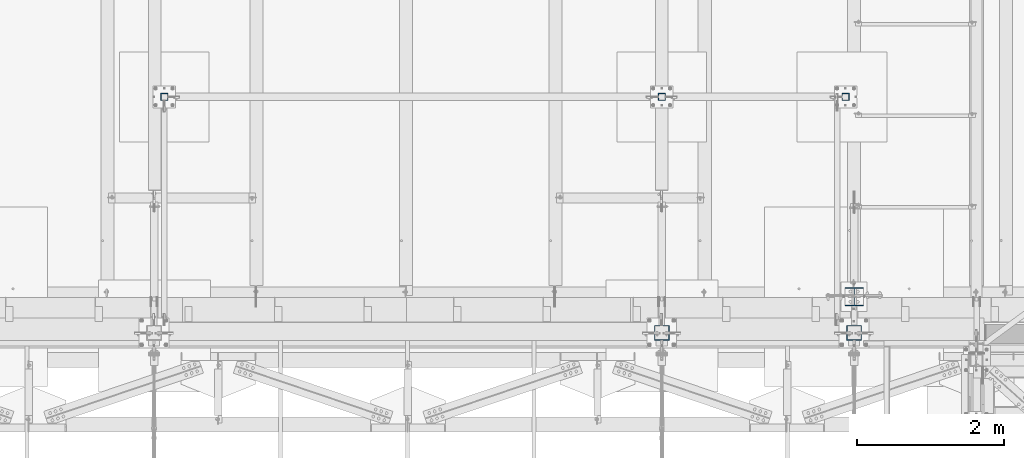
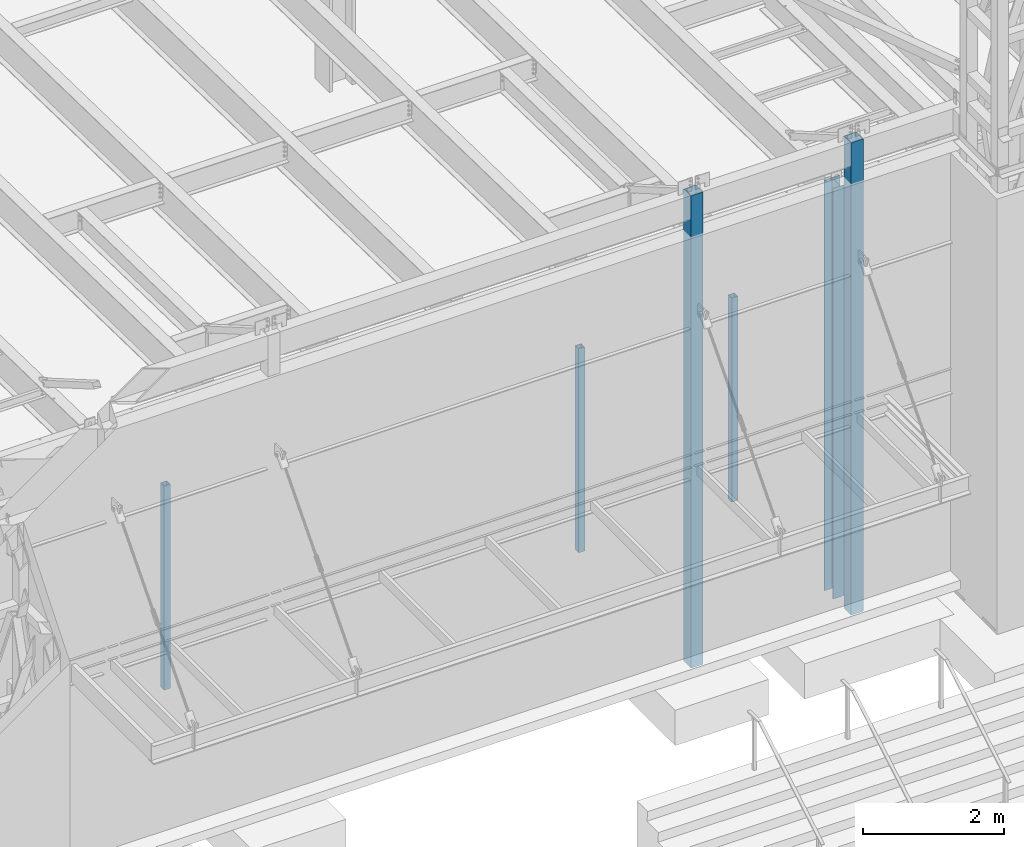
# One storey, part 893 of 1763: 6 columns, 6 elements without a shape of their own.
"""IFC2X3 building model written with IfcOpenShell, lengths in millimetres."""

from ifc_helpers import new_model, si_unit, frame, origin_with_axes, place, context, subcontext, project, spatial, faceted_brep, material, type_object, element, aggregate, save


model = new_model("IFC2X3")

# Units and contexts
model_context = context("Model", 3, precision=1e-05, world=origin_with_axes())
body_context = subcontext(model_context, "Body", "Model", "MODEL_VIEW")
ifc_project = project(units=[si_unit("LENGTHUNIT", "METRE", prefix="MILLI"), si_unit("AREAUNIT", "SQUARE_METRE"), si_unit("VOLUMEUNIT", "CUBIC_METRE"), si_unit("MASSUNIT", "GRAM", prefix="KILO"), si_unit("TIMEUNIT", "SECOND"), si_unit("PLANEANGLEUNIT", "RADIAN"), si_unit("SOLIDANGLEUNIT", "STERADIAN"), si_unit("THERMODYNAMICTEMPERATUREUNIT", "DEGREE_CELSIUS"), si_unit("LUMINOUSINTENSITYUNIT", "LUMEN")], contexts=[model_context])

# Site, building, storey
site_placement = place(None, origin_with_axes())
site = spatial("IfcSite", under=ifc_project, at=site_placement, CompositionType="ELEMENT")
building_placement = place(site_placement, origin_with_axes())
building = spatial("IfcBuilding", under=site, at=building_placement, Name="Undefined", CompositionType="ELEMENT")
storey_placement = place(building_placement, origin_with_axes())
storey = spatial("IfcBuildingStorey", under=building, at=storey_placement, Name="Undefined", CompositionType="ELEMENT", Elevation=0.0)

# Assembly, column
assembly_1_placement = place(storey_placement, origin_with_axes())
assembly_1 = element("IfcElementAssembly", 1, at=assembly_1_placement, inside=storey, Name="COLUMN", AssemblyPlace="NOTDEFINED", PredefinedType="RIGID_FRAME")
ifc_material_1 = material(Name="STEEL/A992")
column_type_1 = type_object("IfcColumnType", Name="W10X49", PredefinedType="NOTDEFINED")
column_1_placement = place(assembly_1_placement, frame((-49402.4372736983, -13716.0, 5029.2), z_axis=(0.0, 1.0, 0.0), x_axis=(0.0, 0.0, 1.0)))
column_1 = element("IfcColumn", 2, at=column_1_placement, type_object=column_type_1, material=ifc_material_1, Name="COLUMN", ObjectType="W10X49", context=body_context, shape_type="Brep", body=[
    faceted_brep([(69.8500000000085, 127.0, -127.0), (69.8500000000085, 127.0, -112.712500000001), (7156.45000000001, 127.0, -112.7125), (7156.45000000001, 127.0, -127.0), (69.8500000000085, 3.96875, -112.712500000001), (7156.45000000001, 3.96875, -112.7125), (69.8500000000085, 3.96875, 112.712500000001), (7156.45000000001, 3.96875, 112.7125), (69.8500000000085, 127.0, 112.712500000001), (7156.45000000001, 127.0, 112.7125), (69.8500000000085, 127.0, 127.0), (7156.45000000001, 127.0, 127.0), (69.8500000000085, -127.0, 127.0), (7156.45000000001, -127.0, 127.0), (69.8500000000085, -127.0, 112.712500000001), (7156.45000000001, -127.0, 112.7125), (69.8500000000085, -3.96875, 112.712500000001), (7156.45000000001, -3.96875, 112.7125), (69.8500000000085, -3.96875, -112.712500000001), (7156.45000000001, -3.96875, -112.7125), (69.8500000000085, -127.0, -112.712500000001), (7156.45000000001, -127.0, -112.7125), (69.8500000000085, -127.0, -127.0), (7156.45000000001, -127.0, -127.0)], [[[0, 1, 2, 3]], [[1, 4, 5, 2]], [[4, 6, 7, 5]], [[6, 8, 9, 7]], [[8, 10, 11, 9]], [[10, 12, 13, 11]], [[12, 14, 15, 13]], [[14, 16, 17, 15]], [[16, 18, 19, 17]], [[18, 20, 21, 19]], [[20, 22, 23, 21]], [[22, 0, 3, 23]], [[5, 7, 9, 11, 13, 15, 17, 19, 21, 23, 3, 2]], [[22, 20, 18, 16, 14, 12, 10, 8, 6, 4, 1, 0]]]),
])
aggregate(assembly_1, [column_1])

assembly_2_placement = place(storey_placement, origin_with_axes())
assembly_2 = element("IfcElementAssembly", 3, at=assembly_2_placement, inside=storey, Name="COLUMN", AssemblyPlace="NOTDEFINED", PredefinedType="RIGID_FRAME")
ifc_material_2 = material()
column_type_2 = type_object("IfcColumnType", Name="HSS4X4X3/8", PredefinedType="NOTDEFINED")
column_2_placement = place(assembly_2_placement, frame((-49516.7540133289, -10998.1999679201, 5029.2), z_axis=(0.0, 1.0, 0.0), x_axis=(0.0, 0.0, 1.0)))
column_2 = element("IfcColumn", 4, at=column_2_placement, type_object=column_type_2, material=ifc_material_2, Name="COLUMN", ObjectType="HSS4X4X3/8", context=body_context, shape_type="Brep", body=[
    faceted_brep([(63.5, 41.2750000000015, -41.2749999999996), (63.5, -41.2750000000015, -41.2749999999996), (3587.75000000128, -41.2750000000015, -41.2749999999996), (3587.75000000128, 41.2750000000015, -41.2749999999996), (63.5, -41.2750000000015, 41.2749999999996), (3587.75000000128, -41.2750000000015, 41.2749999999996), (63.5, 41.2750000000015, 41.2749999999996), (3587.75000000128, 41.2750000000015, 41.2749999999996), (63.5000007629496, 50.8000000000029, -50.7999999999993), (63.5, 50.8000000000029, 50.7999999999993), (3587.75000000128, 50.8000000000029, 50.7999999999993), (3587.75000000128, 50.8000000000029, -50.7999999999993), (63.5, -50.8000000000029, 50.7999999999993), (3587.75000000128, -50.8000000000029, 50.7999999999993), (63.5000007629496, -50.8000000000029, -50.7999999999993), (3587.75000000128, -50.8000000000029, -50.7999999999993)], [[[0, 1, 2, 3]], [[1, 4, 5, 2]], [[4, 6, 7, 5]], [[6, 0, 3, 7]], [[8, 9, 10, 11]], [[9, 12, 13, 10]], [[12, 14, 15, 13]], [[14, 8, 11, 15]], [[13, 15, 11, 10], [5, 7, 3, 2]], [[14, 12, 9, 8], [6, 4, 1, 0]]]),
])
aggregate(assembly_2, [column_2])

assembly_3_placement = place(storey_placement, origin_with_axes())
assembly_3 = element("IfcElementAssembly", 5, at=assembly_3_placement, inside=storey, Name="COLUMN", AssemblyPlace="NOTDEFINED", PredefinedType="RIGID_FRAME")
column_3_placement = place(assembly_3_placement, frame((-52018.6372736983, -10998.1999679201, 5029.2), z_axis=(0.0, 1.0, 0.0), x_axis=(0.0, 0.0, 1.0)))
column_3 = element("IfcColumn", 6, at=column_3_placement, type_object=column_type_2, material=ifc_material_2, Name="COLUMN", ObjectType="HSS4X4X3/8", context=body_context, shape_type="Brep", body=[
    faceted_brep([(63.5, 41.2750000000015, -41.2749999999996), (63.5, -41.2750000000015, -41.2749999999996), (3587.75000000128, -41.2750000000015, -41.2749999999996), (3587.75000000128, 41.2750000000015, -41.2749999999996), (63.5, -41.2750000000015, 41.2749999999996), (3587.75000000128, -41.2750000000015, 41.2749999999996), (63.5, 41.2750000000015, 41.2749999999996), (3587.75000000128, 41.2750000000015, 41.2749999999996), (63.5000007629496, 50.8000000000029, -50.7999999999993), (63.5, 50.8000000000029, 50.7999999999993), (3587.75000000128, 50.8000000000029, 50.7999999999993), (3587.75000000128, 50.8000000000029, -50.7999999999993), (63.5, -50.8000000000029, 50.7999999999993), (3587.75000000128, -50.8000000000029, 50.7999999999993), (63.5000007629496, -50.8000000000029, -50.7999999999993), (3587.75000000128, -50.8000000000029, -50.7999999999993)], [[[0, 1, 2, 3]], [[1, 4, 5, 2]], [[4, 6, 7, 5]], [[6, 0, 3, 7]], [[8, 9, 10, 11]], [[9, 12, 13, 10]], [[12, 14, 15, 13]], [[14, 8, 11, 15]], [[13, 15, 11, 10], [5, 7, 3, 2]], [[14, 12, 9, 8], [6, 4, 1, 0]]]),
])
aggregate(assembly_3, [column_3])

assembly_4_placement = place(storey_placement, origin_with_axes())
assembly_4 = element("IfcElementAssembly", 7, at=assembly_4_placement, inside=storey, Name="COLUMN", AssemblyPlace="NOTDEFINED", PredefinedType="RIGID_FRAME")
column_4_placement = place(assembly_4_placement, frame((-58787.7367867304, -10998.2, 5029.2), z_axis=(0.0, 1.0, 0.0), x_axis=(0.0, 0.0, 1.0)))
column_4 = element("IfcColumn", 8, at=column_4_placement, type_object=column_type_2, material=ifc_material_2, Name="COLUMN", ObjectType="HSS4X4X3/8", context=body_context, shape_type="Brep", body=[
    faceted_brep([(63.5, 41.2750000000015, -41.2749999999996), (63.5, -41.2750000000015, -41.2749999999996), (3587.75000000128, -41.2750000000015, -41.2749999999996), (3587.75000000128, 41.2750000000015, -41.2749999999996), (63.5, -41.2750000000015, 41.2749999999996), (3587.75000000128, -41.2750000000015, 41.2749999999996), (63.5, 41.2750000000015, 41.2749999999996), (3587.75000000128, 41.2750000000015, 41.2749999999996), (63.5000007629496, 50.8000000000029, -50.7999999999993), (63.5, 50.8000000000029, 50.7999999999993), (3587.75000000128, 50.8000000000029, 50.7999999999993), (3587.75000000128, 50.8000000000029, -50.7999999999993), (63.5, -50.8000000000029, 50.7999999999993), (3587.75000000128, -50.8000000000029, 50.7999999999993), (63.5000007629496, -50.8000000000029, -50.7999999999993), (3587.75000000128, -50.8000000000029, -50.7999999999993)], [[[0, 1, 2, 3]], [[1, 4, 5, 2]], [[4, 6, 7, 5]], [[6, 0, 3, 7]], [[8, 9, 10, 11]], [[9, 12, 13, 10]], [[12, 14, 15, 13]], [[14, 8, 11, 15]], [[13, 15, 11, 10], [5, 7, 3, 2]], [[14, 12, 9, 8], [6, 4, 1, 0]]]),
])
aggregate(assembly_4, [column_4])

assembly_5_placement = place(storey_placement, origin_with_axes())
assembly_5 = element("IfcElementAssembly", 9, at=assembly_5_placement, inside=storey, Name="COLUMN", AssemblyPlace="NOTDEFINED", PredefinedType="RIGID_FRAME")
column_type_3 = type_object("IfcColumnType", Name="HSS8X8X3/8", PredefinedType="NOTDEFINED")
column_5_placement = place(assembly_5_placement, frame((-52018.627008321, -14208.1275894107, 5029.2), z_axis=(0.0, 1.0, 0.0), x_axis=(0.0, 0.0, 1.0)))
column_5 = element("IfcColumn", 10, at=column_5_placement, type_object=column_type_3, material=ifc_material_2, Name="COLUMN", ObjectType="HSS8X8X3/8", context=body_context, shape_type="Brep", body=[
    faceted_brep([(69.8499999999976, 92.0749999999971, -92.0750000000007), (69.8499999999976, -92.0749999999971, -92.0750000000007), (8223.25000000128, -92.0749999999971, -92.0750000000007), (8223.25000000128, 92.0749999999971, -92.0750000000007), (69.8499999999976, -92.0749999999971, 92.0750000000007), (8223.25000000128, -92.0749999999971, 92.0750000000007), (69.8499999999976, 92.0749999999971, 92.0750000000007), (8223.25000000128, 92.0749999999971, 92.0750000000007), (69.8499999999976, 101.599999999999, -101.6), (69.8499999999976, 101.599999999999, 101.6), (8223.25000000128, 101.599999999999, 101.6), (8223.25000000128, 101.599999999999, -101.6), (69.8499999999976, -101.599999999999, 101.6), (8223.25000000128, -101.599999999999, 101.6), (69.8499999999976, -101.599999999999, -101.6), (8223.25000000128, -101.599999999999, -101.6)], [[[0, 1, 2, 3]], [[1, 4, 5, 2]], [[4, 6, 7, 5]], [[6, 0, 3, 7]], [[8, 9, 10, 11]], [[9, 12, 13, 10]], [[12, 14, 15, 13]], [[14, 8, 11, 15]], [[13, 15, 11, 10], [5, 7, 3, 2]], [[14, 12, 9, 8], [6, 4, 1, 0]]]),
])
aggregate(assembly_5, [column_5])

assembly_6_placement = place(storey_placement, origin_with_axes())
assembly_6 = element("IfcElementAssembly", 11, at=assembly_6_placement, inside=storey, Name="COLUMN", AssemblyPlace="NOTDEFINED", PredefinedType="RIGID_FRAME")
column_6_placement = place(assembly_6_placement, frame((-49402.4270083209, -14208.1276214144, 5029.2), z_axis=(0.0, 1.0, 0.0), x_axis=(0.0, 0.0, 1.0)))
column_6 = element("IfcColumn", 12, at=column_6_placement, type_object=column_type_3, material=ifc_material_2, Name="COLUMN", ObjectType="HSS8X8X3/8", context=body_context, shape_type="Brep", body=[
    faceted_brep([(69.8499999999976, 92.0749999999971, -92.0750000000007), (69.8499999999976, -92.0749999999971, -92.0750000000007), (8223.27212579575, -92.0749999999971, -92.0750000000007), (8223.27212579575, 92.0749999999971, -92.0750000000007), (69.8499999999976, -92.0749999999971, 92.0750000000007), (8223.27212579575, -92.0749999999971, 92.0750000000007), (69.8499999999976, 92.0749999999971, 92.0750000000007), (8223.27212579575, 92.0749999999971, 92.0750000000007), (69.8499999999976, 101.599999999999, -101.6), (69.8499999999976, 101.599999999999, 101.6), (8223.27212579575, 101.599999999999, 101.6), (8223.27212579575, 101.599999999999, -101.6), (69.8499999999976, -101.599999999999, 101.6), (8223.27212579575, -101.599999999999, 101.6), (69.8499999999976, -101.599999999999, -101.6), (8223.27212579575, -101.599999999999, -101.6)], [[[0, 1, 2, 3]], [[1, 4, 5, 2]], [[4, 6, 7, 5]], [[6, 0, 3, 7]], [[8, 9, 10, 11]], [[9, 12, 13, 10]], [[12, 14, 15, 13]], [[14, 8, 11, 15]], [[13, 15, 11, 10], [5, 7, 3, 2]], [[14, 12, 9, 8], [6, 4, 1, 0]]]),
])
aggregate(assembly_6, [column_6])

save(model, "model.ifc")
